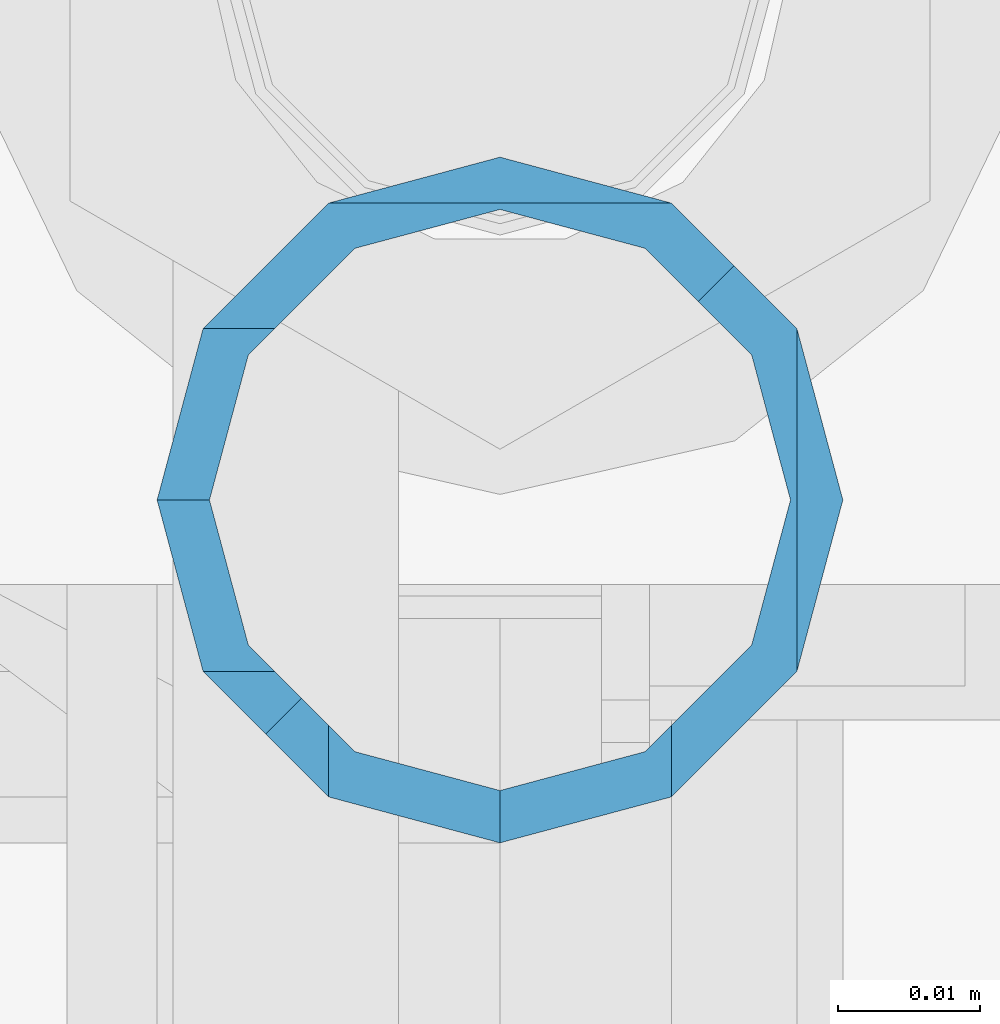
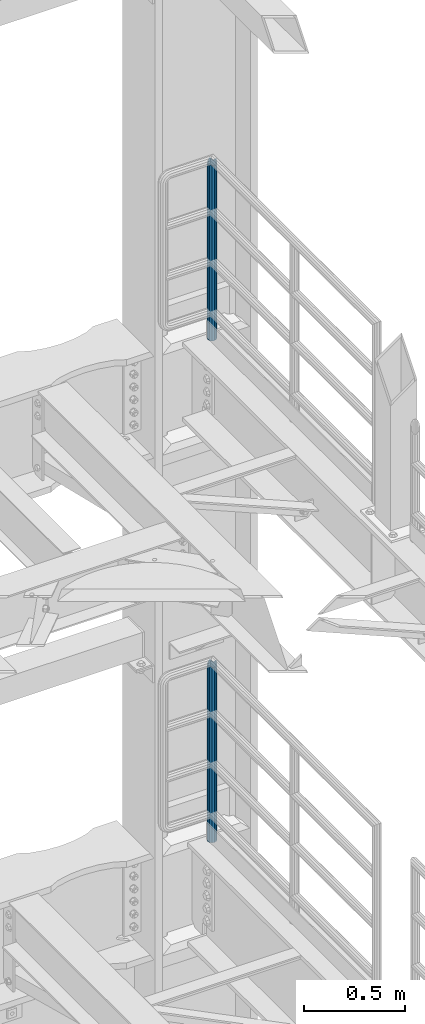
# One storey, part 772 of 1876: 2 columns, 2 elements without a shape of their own.
"""IFC2X3 building model written with IfcOpenShell, lengths in millimetres."""

from ifc_helpers import new_model, si_unit, frame, origin_with_axes, place, context, subcontext, project, spatial, faceted_brep, material, type_object, element, aggregate, save


model = new_model("IFC2X3")

# Units and contexts
model_context = context("Model", 3, precision=1e-05, world=origin_with_axes())
body_context = subcontext(model_context, "Body", "Model", "MODEL_VIEW")
ifc_project = project(units=[si_unit("LENGTHUNIT", "METRE", prefix="MILLI"), si_unit("AREAUNIT", "SQUARE_METRE"), si_unit("VOLUMEUNIT", "CUBIC_METRE"), si_unit("MASSUNIT", "GRAM", prefix="KILO"), si_unit("TIMEUNIT", "SECOND"), si_unit("PLANEANGLEUNIT", "RADIAN"), si_unit("SOLIDANGLEUNIT", "STERADIAN"), si_unit("THERMODYNAMICTEMPERATUREUNIT", "DEGREE_CELSIUS"), si_unit("LUMINOUSINTENSITYUNIT", "LUMEN")], contexts=[model_context])

# Site, building, storey
site_placement = place(None, origin_with_axes())
site = spatial("IfcSite", under=ifc_project, at=site_placement, CompositionType="ELEMENT")
building_placement = place(site_placement, origin_with_axes())
building = spatial("IfcBuilding", under=site, at=building_placement, Name="Undefined", CompositionType="ELEMENT")
storey_placement = place(building_placement, origin_with_axes())
storey = spatial("IfcBuildingStorey", under=building, at=storey_placement, Name="Undefined", CompositionType="ELEMENT", Elevation=0.0)

# Assembly, column
assembly_1_placement = place(storey_placement, origin_with_axes())
assembly_1 = element("IfcElementAssembly", 1, at=assembly_1_placement, inside=storey, Name="RAIL", AssemblyPlace="NOTDEFINED", PredefinedType="RIGID_FRAME")
ifc_material = material()
column_type = type_object("IfcColumnType", Name="PIPE1-1/2SCH40", PredefinedType="NOTDEFINED")
column_1_placement = place(assembly_1_placement, frame((7620.0, 13499.7063, 8153.4), z_axis=(0.0, 1.0, 0.0), x_axis=(0.0, 0.0, 1.0)))
column_1 = element("IfcColumn", 2, at=column_1_placement, type_object=column_type, material=ifc_material, Name="POST", ObjectType="PIPE1-1/2SCH40", context=body_context, shape_type="Brep", body=[
    faceted_brep([(1076.325, 24.1300000000001, 0.0), (1064.26, 20.8971929933184, 12.0649999999996), (1064.25999999999, 20.8971929933186, -12.0649999999996), (1059.84389372958, 16.4810867391689, 16.4811062541503), (1057.32835795224, 13.9655509593422, 13.9655704718371), (1061.07042843786, 17.7076214311803, 10.2235000000001), (1063.80980700668, 20.4469999999999, 0.0), (1061.07042843786, 17.7076214311803, -10.2235000000001), (1055.42780700668, 12.0650000000001, -15.8661214311805), (1055.42780700667, 12.0649999999996, -20.8971929933186), (1054.93437856882, 10.2235000000001, -17.7076214311801), (1052.195, 0.0, -20.4470000000001), (1052.19499999999, 0.0, -24.1300000000001), (1055.42780700668, -12.0650000000001, -15.8661214311805), (1055.42780700667, -12.0649999999996, -20.8971929933186), (1054.93437856882, -10.2235000000001, -17.7076214311801), (1057.32837749231, -13.9655704718352, -13.9655509593449), (1059.84391327711, -16.4811062541476, -16.4810867391716), (1055.42780700668, -15.8661214311742, -12.065000000006), (1055.42780700668, -20.8971929933184, -12.0649999999996), (1054.93437856882, -17.7076214311801, -10.2235000000001), (1052.195, -20.4470000000001, 0.0), (1052.195, -24.1300000000001, 0.0), (1054.93437856882, -17.7076214311801, 10.2235000000001), (1055.42780700668, -15.8661214311869, 12.0649999999932), (1055.42780700668, -20.8971929933184, 12.0649999999996), (1076.325, 0.0, 24.1300000000001), (1064.26, -12.0650000000001, 20.8971929933186), (1064.26, 12.065, 20.8971929933186), (1061.07042843787, -10.2235000000001, 17.7076214311801), (1063.80980700669, 0.0, 20.4470000000001), (1061.07042843787, 10.2235000000001, 17.7076214311801), (0.0, -20.8971929933184, -12.0649999999996), (0.0, -12.0650000000001, -20.8971929933186), (-1.45519152283669e-11, 0.0, -24.130000000001), (0.0, 12.0650000000001, -20.8971929933186), (0.0, 20.8971929933184, -12.0649999999996), (0.0, 24.1299999999992, 0.0), (0.0, 20.8971929933184, 12.0649999999996), (0.0, 12.0650000000001, 20.8971929933186), (-1.45519152283669e-11, 0.0, 24.130000000001), (0.0, -20.8971929933184, 12.0649999999996), (0.0, -24.1299999999992, 0.0), (0.0, -12.0650000000001, 20.8971929933186), (0.0, -17.7076214311803, -10.2235000000001), (0.0, -10.2235000000001, -17.7076214311801), (-1.45519152283669e-11, 0.0, -20.4470000000001), (0.0, 10.2235000000001, -17.7076214311801), (0.0, 17.7076214311803, -10.2235000000001), (0.0, 20.4469999999999, 0.0), (0.0, 17.7076214311803, 10.2235000000001), (0.0, 10.2235000000001, 17.7076214311801), (-1.45519152283669e-11, 0.0, 20.4470000000001), (0.0, -10.2235000000001, 17.7076214311801), (0.0, -17.7076214311803, 10.2235000000001), (0.0, -20.4469999999999, 0.0)], [[[0, 1, 2]], [[3, 4, 5, 6, 7, 8, 9, 2, 1]], [[10, 11, 12, 9, 8]], [[13, 14, 12, 11, 15]], [[14, 13, 16, 17]], [[17, 16, 18, 19]], [[19, 18, 20, 21, 22]], [[22, 21, 23, 24, 25]], [[26, 27, 28]], [[25, 24, 29, 30, 31, 4, 3, 28, 27]], [[32, 33, 14, 17, 19]], [[33, 34, 12, 14]], [[34, 35, 9, 12]], [[35, 36, 2, 9]], [[36, 37, 0, 2]], [[37, 38, 1, 0]], [[1, 38, 39, 28, 3]], [[39, 40, 26, 28]], [[41, 42, 22, 25]], [[43, 41, 25, 27]], [[40, 43, 27, 26]], [[42, 32, 19, 22]], [[41, 43, 40, 39, 38, 37, 36, 35, 34, 33, 32, 42], [44, 45, 46, 47, 48, 49, 50, 51, 52, 53, 54, 55]], [[53, 52, 30, 29]], [[23, 54, 53, 29, 24]], [[55, 54, 23, 21]], [[44, 55, 21, 20]], [[15, 45, 44, 20, 18, 16, 13]], [[46, 45, 15, 11]], [[47, 46, 11, 10]], [[48, 47, 10, 8, 7]], [[49, 48, 7, 6]], [[50, 49, 6, 5]], [[51, 50, 5, 4, 31]], [[52, 51, 31, 30]]]),
])
aggregate(assembly_1, [column_1])

assembly_2_placement = place(storey_placement, origin_with_axes())
assembly_2 = element("IfcElementAssembly", 3, at=assembly_2_placement, inside=storey, Name="RAIL", AssemblyPlace="NOTDEFINED", PredefinedType="RIGID_FRAME")
column_2_placement = place(assembly_2_placement, frame((7620.0, 13499.7063, 5130.8), z_axis=(0.0, 1.0, 0.0), x_axis=(0.0, 0.0, 1.0)))
column_2 = element("IfcColumn", 4, at=column_2_placement, type_object=column_type, material=ifc_material, Name="POST", ObjectType="PIPE1-1/2SCH40", context=body_context, shape_type="Brep", body=[
    faceted_brep([(1076.325, 24.1300000000001, 0.0), (1064.26, 20.8971929933184, 12.0649999999996), (1064.25999999999, 20.8971929933186, -12.0649999999996), (1059.84389372958, 16.4810867391689, 16.4811062541503), (1057.32835795224, 13.9655509593422, 13.9655704718371), (1061.07042843786, 17.7076214311803, 10.2235000000001), (1063.80980700668, 20.4469999999999, 0.0), (1061.07042843786, 17.7076214311803, -10.2235000000001), (1055.42780700668, 12.0650000000001, -15.8661214311805), (1055.42780700667, 12.0649999999996, -20.8971929933186), (1054.93437856882, 10.2235000000001, -17.7076214311801), (1052.195, 0.0, -20.4470000000001), (1052.19499999999, 0.0, -24.1300000000001), (1055.42780700668, -12.0650000000001, -15.8661214311805), (1055.42780700667, -12.0649999999996, -20.8971929933186), (1054.93437856882, -10.2235000000001, -17.7076214311801), (1057.32837749231, -13.9655704718352, -13.9655509593449), (1059.84391327711, -16.4811062541476, -16.4810867391716), (1055.42780700668, -15.8661214311742, -12.065000000006), (1055.42780700668, -20.8971929933184, -12.0649999999996), (1054.93437856882, -17.7076214311801, -10.2235000000001), (1052.195, -20.4470000000001, 0.0), (1052.195, -24.1300000000001, 0.0), (1054.93437856882, -17.7076214311801, 10.2235000000001), (1055.42780700668, -15.8661214311869, 12.0649999999932), (1055.42780700668, -20.8971929933184, 12.0649999999996), (1076.325, 0.0, 24.1300000000001), (1064.26, -12.0650000000001, 20.8971929933186), (1064.26, 12.065, 20.8971929933186), (1061.07042843787, -10.2235000000001, 17.7076214311801), (1063.80980700669, 0.0, 20.4470000000001), (1061.07042843787, 10.2235000000001, 17.7076214311801), (0.0, -20.8971929933184, -12.0649999999996), (0.0, -12.0650000000001, -20.8971929933186), (-1.45519152283669e-11, 0.0, -24.130000000001), (0.0, 12.0650000000001, -20.8971929933186), (0.0, 20.8971929933184, -12.0649999999996), (0.0, 24.1299999999992, 0.0), (0.0, 20.8971929933184, 12.0649999999996), (0.0, 12.0650000000001, 20.8971929933186), (-1.45519152283669e-11, 0.0, 24.130000000001), (0.0, -20.8971929933184, 12.0649999999996), (0.0, -24.1299999999992, 0.0), (0.0, -12.0650000000001, 20.8971929933186), (0.0, -17.7076214311803, -10.2235000000001), (0.0, -10.2235000000001, -17.7076214311801), (-1.45519152283669e-11, 0.0, -20.4470000000001), (0.0, 10.2235000000001, -17.7076214311801), (0.0, 17.7076214311803, -10.2235000000001), (0.0, 20.4469999999999, 0.0), (0.0, 17.7076214311803, 10.2235000000001), (0.0, 10.2235000000001, 17.7076214311801), (-1.45519152283669e-11, 0.0, 20.4470000000001), (0.0, -10.2235000000001, 17.7076214311801), (0.0, -17.7076214311803, 10.2235000000001), (0.0, -20.4469999999999, 0.0)], [[[0, 1, 2]], [[3, 4, 5, 6, 7, 8, 9, 2, 1]], [[10, 11, 12, 9, 8]], [[13, 14, 12, 11, 15]], [[14, 13, 16, 17]], [[17, 16, 18, 19]], [[19, 18, 20, 21, 22]], [[22, 21, 23, 24, 25]], [[26, 27, 28]], [[25, 24, 29, 30, 31, 4, 3, 28, 27]], [[32, 33, 14, 17, 19]], [[33, 34, 12, 14]], [[34, 35, 9, 12]], [[35, 36, 2, 9]], [[36, 37, 0, 2]], [[37, 38, 1, 0]], [[1, 38, 39, 28, 3]], [[39, 40, 26, 28]], [[41, 42, 22, 25]], [[43, 41, 25, 27]], [[40, 43, 27, 26]], [[42, 32, 19, 22]], [[41, 43, 40, 39, 38, 37, 36, 35, 34, 33, 32, 42], [44, 45, 46, 47, 48, 49, 50, 51, 52, 53, 54, 55]], [[53, 52, 30, 29]], [[23, 54, 53, 29, 24]], [[55, 54, 23, 21]], [[44, 55, 21, 20]], [[15, 45, 44, 20, 18, 16, 13]], [[46, 45, 15, 11]], [[47, 46, 11, 10]], [[48, 47, 10, 8, 7]], [[49, 48, 7, 6]], [[50, 49, 6, 5]], [[51, 50, 5, 4, 31]], [[52, 51, 31, 30]]]),
])
aggregate(assembly_2, [column_2])

save(model, "model.ifc")
